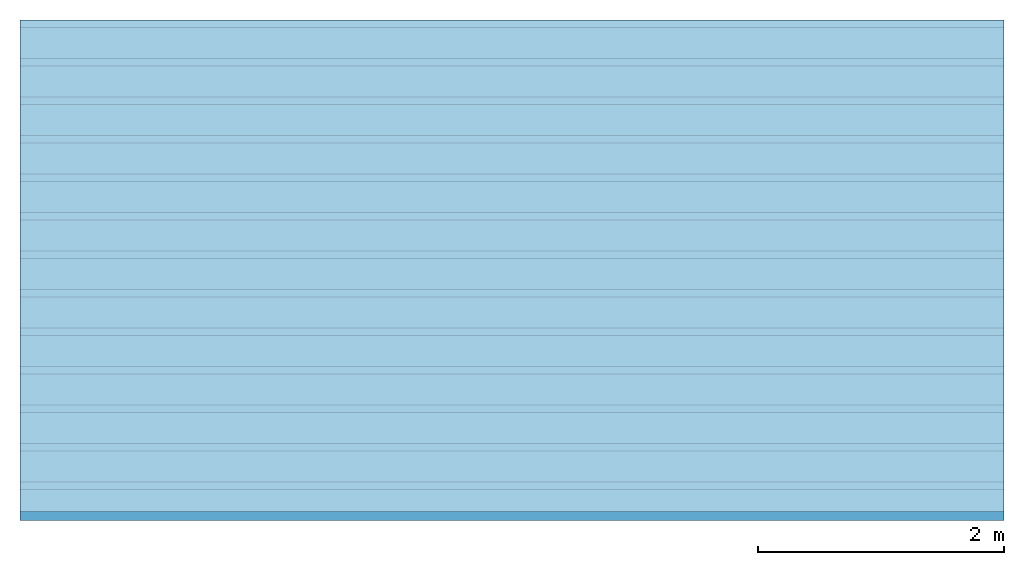
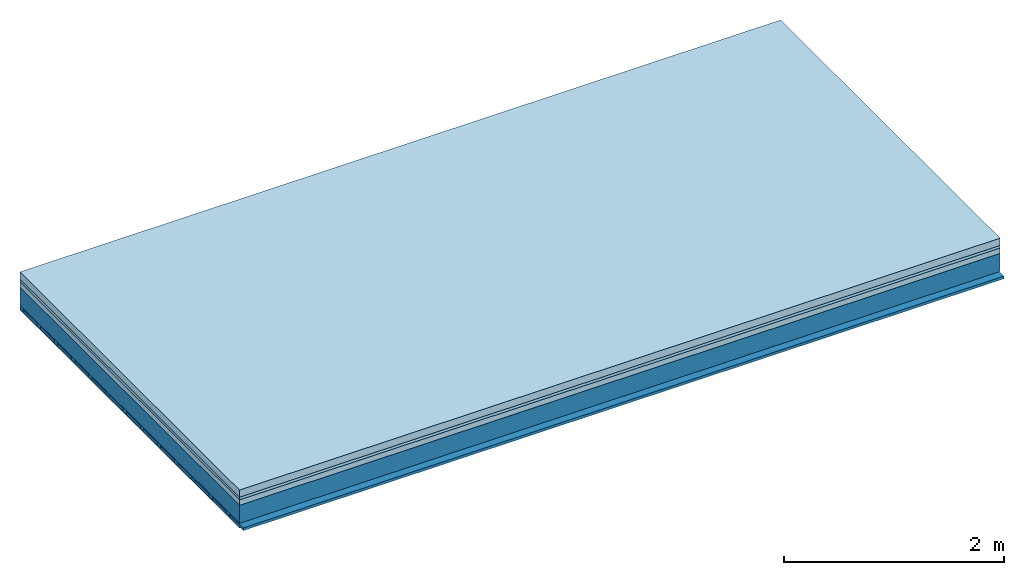
# One storey: 4 plates, 3 members, 1 element without a shape of its own.
"""IFC4 building model written with IfcOpenShell, lengths in metres."""

from ifc_helpers import new_model, si_unit, derived_unit, direction, frame, frame_2d, origin, origin_with_axes, place, context, project, spatial, rectangle, extrude, material, layer, layer_set, type_object, element, aggregate, save


model = new_model("IFC4")

# Units and contexts
plan_context = context("Plan", 3, precision=1e-05, world=origin(), true_north=direction((0.0, 1.0)))
model_context = context("Model", 3, precision=1e-05, world=origin(), true_north=direction((0.0, 1.0)))
ifc_project = project(units=[si_unit("LENGTHUNIT", "METRE"), derived_unit("SOUNDPRESSUREUNIT", [(si_unit("PRESSUREUNIT", "PASCAL", prefix="MICRO"), 0)]), si_unit("ENERGYUNIT", "JOULE", prefix="MEGA"), si_unit("MASSUNIT", "GRAM", prefix="KILO"), derived_unit("THERMALTRANSMITTANCEUNIT", [(si_unit("POWERUNIT", "WATT"), 1), (si_unit("AREAUNIT", "SQUARE_METRE"), -1), (si_unit("THERMODYNAMICTEMPERATUREUNIT", "KELVIN"), -1)]), derived_unit("AREADENSITYUNIT", [(si_unit("MASSUNIT", "GRAM", prefix="KILO"), 1), (si_unit("AREAUNIT", "SQUARE_METRE"), -1)]), derived_unit("USERDEFINED", [(si_unit("ENERGYUNIT", "JOULE", prefix="MEGA"), 1), (si_unit("AREAUNIT", "SQUARE_METRE"), -1)])], contexts=[plan_context, model_context])

# Site, building, storey
site = spatial("IfcSite", under=ifc_project)
building_placement = place(None, origin())
building = spatial("IfcBuilding", under=site, at=building_placement)
storey_placement = place(building_placement, origin())
storey = spatial("IfcBuildingStorey", under=building, at=storey_placement)

# Slab, members, plates
ifc_material_1 = material(Name="Cement screed", Category="04.006")
ifc_layer_1 = layer(ifc_material_1, 0.08, Name="On-material")
ifc_material_2 = material()
ifc_layer_2 = layer(ifc_material_2, 0.03, Name="Impact sound insulation")
ifc_material_3 = material(Category="03.011")
ifc_layer_3 = layer(ifc_material_3, 0.06, Name="on Supporting structure")
ifc_layer_4 = layer(None, 0.2, Name="Supporting structure")
ifc_material_4 = material(Name="of the art")
ifc_layer_5 = layer(ifc_material_4, 0.0, Name="Bond")
ifc_layer_6 = layer(None, 0.04, Name="Battens / profiles")
ifc_material_5 = material(Category="03.007")
ifc_layer_7 = layer(ifc_material_5, 0.015, Name="Ceiling covering 1st layer")
ifc_material_6 = material(Name="Glued joints")
ifc_layer_8 = layer(ifc_material_6, 0.0, Name="Surface / treatment")
ifc_layer_set = layer_set([ifc_layer_1, ifc_layer_2, ifc_layer_3, ifc_layer_4, ifc_layer_5, ifc_layer_6, ifc_layer_7, ifc_layer_8])
slab_type = type_object("IfcSlabType", Name="A1108", PredefinedType="NOTDEFINED", material=ifc_layer_set)
slab_placement = place(None, frame((0.0, 0.0, 0.0), z_axis=(0.0, 0.0, -1.0), x_axis=(1.0, 0.0, 0.0)))
slab = element("IfcSlab", 1, at=slab_placement, inside=storey, type_object=slab_type, material=ifc_layer_set, Name="Slab #1")
ifc_material_7 = material()
member_1_placement = place(slab_placement, origin())
member_1 = element("IfcMember", 2, at=member_1_placement, material=ifc_material_7, Name="Supporting structure", context=plan_context, shape_type="SweptSolid", body=[
    extrude(rectangle(XDim=1.0, YDim=0.2, at=frame_2d((0.5, 0.1), x_axis=(1.0, 0.0))), frame((0.0, 4.0, 0.17), z_axis=(0.0, -1.0, 0.0), x_axis=(1.0, 0.0, 0.0)), (0.0, 0.0, 1.0), 4.0),
    extrude(rectangle(XDim=1.0, YDim=0.2, at=frame_2d((0.5, 0.1), x_axis=(1.0, 0.0))), frame((1.0, 4.0, 0.17), z_axis=(0.0, -1.0, 0.0), x_axis=(1.0, 0.0, 0.0)), (0.0, 0.0, 1.0), 4.0),
    extrude(rectangle(XDim=1.0, YDim=0.2, at=frame_2d((0.5, 0.1), x_axis=(1.0, 0.0))), frame((2.0, 4.0, 0.17), z_axis=(0.0, -1.0, 0.0), x_axis=(1.0, 0.0, 0.0)), (0.0, 0.0, 1.0), 4.0),
    extrude(rectangle(XDim=1.0, YDim=0.2, at=frame_2d((0.5, 0.1), x_axis=(1.0, 0.0))), frame((3.0, 4.0, 0.17), z_axis=(0.0, -1.0, 0.0), x_axis=(1.0, 0.0, 0.0)), (0.0, 0.0, 1.0), 4.0),
    extrude(rectangle(XDim=1.0, YDim=0.2, at=frame_2d((0.5, 0.1), x_axis=(1.0, 0.0))), frame((4.0, 4.0, 0.17), z_axis=(0.0, -1.0, 0.0), x_axis=(1.0, 0.0, 0.0)), (0.0, 0.0, 1.0), 4.0),
    extrude(rectangle(XDim=1.0, YDim=0.2, at=frame_2d((0.5, 0.1), x_axis=(1.0, 0.0))), frame((5.0, 4.0, 0.17), z_axis=(0.0, -1.0, 0.0), x_axis=(1.0, 0.0, 0.0)), (0.0, 0.0, 1.0), 4.0),
    extrude(rectangle(XDim=1.0, YDim=0.2, at=frame_2d((0.5, 0.1), x_axis=(1.0, 0.0))), frame((6.0, 4.0, 0.17), z_axis=(0.0, -1.0, 0.0), x_axis=(1.0, 0.0, 0.0)), (0.0, 0.0, 1.0), 4.0),
    extrude(rectangle(XDim=1.0, YDim=0.2, at=frame_2d((0.5, 0.1), x_axis=(1.0, 0.0))), frame((7.0, 4.0, 0.17), z_axis=(0.0, -1.0, 0.0), x_axis=(1.0, 0.0, 0.0)), (0.0, 0.0, 1.0), 4.0),
])
ifc_material_8 = material()
member_2_placement = place(slab_placement, origin())
member_2 = element("IfcMember", 3, at=member_2_placement, material=ifc_material_8, Name="Battens / profiles", context=plan_context, shape_type="SweptSolid", body=[
    extrude(rectangle(XDim=0.06, YDim=0.04, at=frame_2d((0.03, 0.02), x_axis=(1.0, 0.0))), frame((0.0, 0.0, 0.37), z_axis=(1.0, 0.0, 0.0), x_axis=(0.0, 1.0, 0.0)), (0.0, 0.0, 1.0), 8.0),
    extrude(rectangle(XDim=0.06, YDim=0.04, at=frame_2d((0.03, 0.02), x_axis=(1.0, 0.0))), frame((0.0, 0.313, 0.37), z_axis=(1.0, 0.0, 0.0), x_axis=(0.0, 1.0, 0.0)), (0.0, 0.0, 1.0), 8.0),
    extrude(rectangle(XDim=0.06, YDim=0.04, at=frame_2d((0.03, 0.02), x_axis=(1.0, 0.0))), frame((0.0, 0.626, 0.37), z_axis=(1.0, 0.0, 0.0), x_axis=(0.0, 1.0, 0.0)), (0.0, 0.0, 1.0), 8.0),
    extrude(rectangle(XDim=0.06, YDim=0.04, at=frame_2d((0.03, 0.02), x_axis=(1.0, 0.0))), frame((0.0, 0.939, 0.37), z_axis=(1.0, 0.0, 0.0), x_axis=(0.0, 1.0, 0.0)), (0.0, 0.0, 1.0), 8.0),
    extrude(rectangle(XDim=0.06, YDim=0.04, at=frame_2d((0.03, 0.02), x_axis=(1.0, 0.0))), frame((0.0, 1.252, 0.37), z_axis=(1.0, 0.0, 0.0), x_axis=(0.0, 1.0, 0.0)), (0.0, 0.0, 1.0), 8.0),
    extrude(rectangle(XDim=0.06, YDim=0.04, at=frame_2d((0.03, 0.02), x_axis=(1.0, 0.0))), frame((0.0, 1.565, 0.37), z_axis=(1.0, 0.0, 0.0), x_axis=(0.0, 1.0, 0.0)), (0.0, 0.0, 1.0), 8.0),
    extrude(rectangle(XDim=0.06, YDim=0.04, at=frame_2d((0.03, 0.02), x_axis=(1.0, 0.0))), frame((0.0, 1.878, 0.37), z_axis=(1.0, 0.0, 0.0), x_axis=(0.0, 1.0, 0.0)), (0.0, 0.0, 1.0), 8.0),
    extrude(rectangle(XDim=0.06, YDim=0.04, at=frame_2d((0.03, 0.02), x_axis=(1.0, 0.0))), frame((0.0, 2.191, 0.37), z_axis=(1.0, 0.0, 0.0), x_axis=(0.0, 1.0, 0.0)), (0.0, 0.0, 1.0), 8.0),
    extrude(rectangle(XDim=0.06, YDim=0.04, at=frame_2d((0.03, 0.02), x_axis=(1.0, 0.0))), frame((0.0, 2.504, 0.37), z_axis=(1.0, 0.0, 0.0), x_axis=(0.0, 1.0, 0.0)), (0.0, 0.0, 1.0), 8.0),
    extrude(rectangle(XDim=0.06, YDim=0.04, at=frame_2d((0.03, 0.02), x_axis=(1.0, 0.0))), frame((0.0, 2.817, 0.37), z_axis=(1.0, 0.0, 0.0), x_axis=(0.0, 1.0, 0.0)), (0.0, 0.0, 1.0), 8.0),
    extrude(rectangle(XDim=0.06, YDim=0.04, at=frame_2d((0.03, 0.02), x_axis=(1.0, 0.0))), frame((0.0, 3.13, 0.37), z_axis=(1.0, 0.0, 0.0), x_axis=(0.0, 1.0, 0.0)), (0.0, 0.0, 1.0), 8.0),
    extrude(rectangle(XDim=0.06, YDim=0.04, at=frame_2d((0.03, 0.02), x_axis=(1.0, 0.0))), frame((0.0, 3.443, 0.37), z_axis=(1.0, 0.0, 0.0), x_axis=(0.0, 1.0, 0.0)), (0.0, 0.0, 1.0), 8.0),
    extrude(rectangle(XDim=0.06, YDim=0.04, at=frame_2d((0.03, 0.02), x_axis=(1.0, 0.0))), frame((0.0, 3.756, 0.37), z_axis=(1.0, 0.0, 0.0), x_axis=(0.0, 1.0, 0.0)), (0.0, 0.0, 1.0), 8.0),
])
ifc_material_9 = material()
member_3_placement = place(slab_placement, origin())
member_3 = element("IfcMember", 4, at=member_3_placement, material=ifc_material_9, Name="Cavity", context=plan_context, shape_type="SweptSolid", body=[
    extrude(rectangle(XDim=0.253, YDim=0.03, at=frame_2d((0.1265, 0.015), x_axis=(1.0, 0.0))), frame((0.0, 0.06, 0.38), z_axis=(1.0, 0.0, 0.0), x_axis=(0.0, 1.0, 0.0)), (0.0, 0.0, 1.0), 8.0),
    extrude(rectangle(XDim=0.253, YDim=0.03, at=frame_2d((0.1265, 0.015), x_axis=(1.0, 0.0))), frame((0.0, 0.373, 0.38), z_axis=(1.0, 0.0, 0.0), x_axis=(0.0, 1.0, 0.0)), (0.0, 0.0, 1.0), 8.0),
    extrude(rectangle(XDim=0.253, YDim=0.03, at=frame_2d((0.1265, 0.015), x_axis=(1.0, 0.0))), frame((0.0, 0.686, 0.38), z_axis=(1.0, 0.0, 0.0), x_axis=(0.0, 1.0, 0.0)), (0.0, 0.0, 1.0), 8.0),
    extrude(rectangle(XDim=0.253, YDim=0.03, at=frame_2d((0.1265, 0.015), x_axis=(1.0, 0.0))), frame((0.0, 0.999, 0.38), z_axis=(1.0, 0.0, 0.0), x_axis=(0.0, 1.0, 0.0)), (0.0, 0.0, 1.0), 8.0),
    extrude(rectangle(XDim=0.253, YDim=0.03, at=frame_2d((0.1265, 0.015), x_axis=(1.0, 0.0))), frame((0.0, 1.312, 0.38), z_axis=(1.0, 0.0, 0.0), x_axis=(0.0, 1.0, 0.0)), (0.0, 0.0, 1.0), 8.0),
    extrude(rectangle(XDim=0.253, YDim=0.03, at=frame_2d((0.1265, 0.015), x_axis=(1.0, 0.0))), frame((0.0, 1.625, 0.38), z_axis=(1.0, 0.0, 0.0), x_axis=(0.0, 1.0, 0.0)), (0.0, 0.0, 1.0), 8.0),
    extrude(rectangle(XDim=0.253, YDim=0.03, at=frame_2d((0.1265, 0.015), x_axis=(1.0, 0.0))), frame((0.0, 1.938, 0.38), z_axis=(1.0, 0.0, 0.0), x_axis=(0.0, 1.0, 0.0)), (0.0, 0.0, 1.0), 8.0),
    extrude(rectangle(XDim=0.253, YDim=0.03, at=frame_2d((0.1265, 0.015), x_axis=(1.0, 0.0))), frame((0.0, 2.251, 0.38), z_axis=(1.0, 0.0, 0.0), x_axis=(0.0, 1.0, 0.0)), (0.0, 0.0, 1.0), 8.0),
    extrude(rectangle(XDim=0.253, YDim=0.03, at=frame_2d((0.1265, 0.015), x_axis=(1.0, 0.0))), frame((0.0, 2.564, 0.38), z_axis=(1.0, 0.0, 0.0), x_axis=(0.0, 1.0, 0.0)), (0.0, 0.0, 1.0), 8.0),
    extrude(rectangle(XDim=0.253, YDim=0.03, at=frame_2d((0.1265, 0.015), x_axis=(1.0, 0.0))), frame((0.0, 2.877, 0.38), z_axis=(1.0, 0.0, 0.0), x_axis=(0.0, 1.0, 0.0)), (0.0, 0.0, 1.0), 8.0),
    extrude(rectangle(XDim=0.253, YDim=0.03, at=frame_2d((0.1265, 0.015), x_axis=(1.0, 0.0))), frame((0.0, 3.19, 0.38), z_axis=(1.0, 0.0, 0.0), x_axis=(0.0, 1.0, 0.0)), (0.0, 0.0, 1.0), 8.0),
    extrude(rectangle(XDim=0.253, YDim=0.03, at=frame_2d((0.1265, 0.015), x_axis=(1.0, 0.0))), frame((0.0, 3.503, 0.38), z_axis=(1.0, 0.0, 0.0), x_axis=(0.0, 1.0, 0.0)), (0.0, 0.0, 1.0), 8.0),
    extrude(rectangle(XDim=0.253, YDim=0.03, at=frame_2d((0.1265, 0.015), x_axis=(1.0, 0.0))), frame((0.0, 3.816, 0.38), z_axis=(1.0, 0.0, 0.0), x_axis=(0.0, 1.0, 0.0)), (0.0, 0.0, 1.0), 8.0),
])
plate_1_placement = place(slab_placement, origin())
plate_1 = element("IfcPlate", 5, at=plate_1_placement, material=ifc_material_1, Name="On-material", context=plan_context, shape_type="SweptSolid", body=[
    extrude(rectangle(XDim=8.0, YDim=4.0, at=frame_2d((4.0, 2.0), x_axis=(1.0, 0.0))), origin_with_axes(), (0.0, 0.0, 1.0), 0.08),
])
plate_2_placement = place(slab_placement, origin())
plate_2 = element("IfcPlate", 6, at=plate_2_placement, material=ifc_material_2, Name="Impact sound insulation", context=plan_context, shape_type="SweptSolid", body=[
    extrude(rectangle(XDim=8.0, YDim=4.0, at=frame_2d((4.0, 2.0), x_axis=(1.0, 0.0))), frame((0.0, 0.0, 0.08), z_axis=(0.0, 0.0, 1.0), x_axis=(1.0, 0.0, 0.0)), (0.0, 0.0, 1.0), 0.03),
])
plate_3_placement = place(slab_placement, origin())
plate_3 = element("IfcPlate", 7, at=plate_3_placement, material=ifc_material_3, Name="on Supporting structure", context=plan_context, shape_type="SweptSolid", body=[
    extrude(rectangle(XDim=8.0, YDim=4.0, at=frame_2d((4.0, 2.0), x_axis=(1.0, 0.0))), frame((0.0, 0.0, 0.11), z_axis=(0.0, 0.0, 1.0), x_axis=(1.0, 0.0, 0.0)), (0.0, 0.0, 1.0), 0.06),
])
plate_4_placement = place(slab_placement, origin())
plate_4 = element("IfcPlate", 8, at=plate_4_placement, material=ifc_material_5, Name="Ceiling covering 1st layer", context=plan_context, shape_type="SweptSolid", body=[
    extrude(rectangle(XDim=8.0, YDim=4.0, at=frame_2d((4.0, 2.0), x_axis=(1.0, 0.0))), frame((0.0, 0.0, 0.41), z_axis=(0.0, 0.0, 1.0), x_axis=(1.0, 0.0, 0.0)), (0.0, 0.0, 1.0), 0.015),
])
aggregate(slab, [plate_1, plate_2, plate_3, member_1, member_2, member_3, plate_4])

save(model, "model.ifc")
